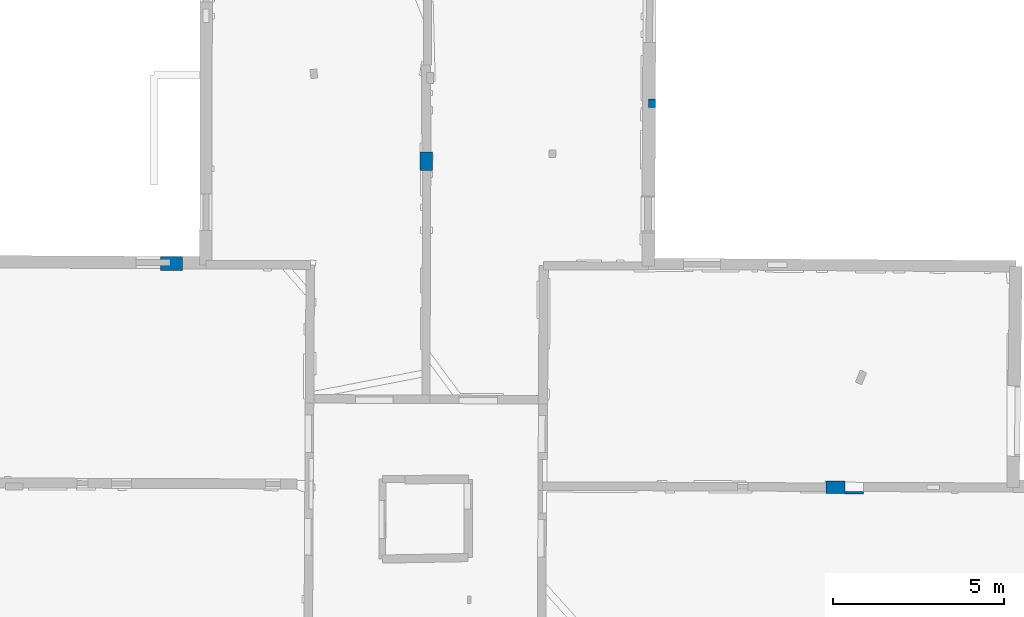
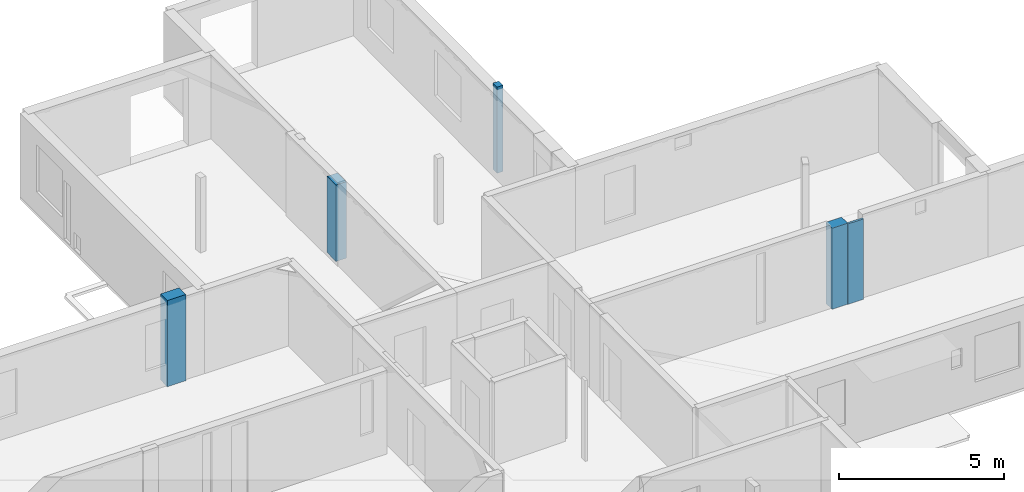
# One storey, part 2 of 17: 5 columns.
"""IFC2X3 building model written with IfcOpenShell, lengths in metres."""

from ifc_helpers import new_model, entity, si_unit, converted_unit, derived_unit, direction, frame, origin, origin_2d_with_axis, place, context, subcontext, project, spatial, rectangle, extrude, source, transform, mapped, material, type_object, type_shapes, element, save


model = new_model("IFC2X3")

# Units and contexts
model_context = context("Model", 3, precision=1e-05, world=origin(), true_north=direction((0.0, 1.0)))
body_context = subcontext(model_context, "Body", "Model", "MODEL_VIEW")
ifc_project = project(units=[si_unit("LENGTHUNIT", "METRE"), si_unit("AREAUNIT", "SQUARE_METRE"), si_unit("VOLUMEUNIT", "CUBIC_METRE"), converted_unit("PLANEANGLEUNIT", "DEGREE", entity("IfcRatioMeasure", 0.0174532925199433), si_unit("PLANEANGLEUNIT", "RADIAN"), dimensions=[0, 0, 0, 0, 0, 0, 0]), si_unit("MASSUNIT", "GRAM", prefix="KILO"), derived_unit("MASSDENSITYUNIT", [(si_unit("MASSUNIT", "GRAM", prefix="KILO"), 1), (si_unit("LENGTHUNIT", "METRE"), -3)]), derived_unit("MOMENTOFINERTIAUNIT", [(si_unit("LENGTHUNIT", "METRE"), 4)]), si_unit("TIMEUNIT", "SECOND"), si_unit("FREQUENCYUNIT", "HERTZ"), si_unit("THERMODYNAMICTEMPERATUREUNIT", "DEGREE_CELSIUS"), derived_unit("THERMALTRANSMITTANCEUNIT", [(si_unit("MASSUNIT", "GRAM", prefix="KILO"), 1), (si_unit("THERMODYNAMICTEMPERATUREUNIT", "KELVIN"), -1), (si_unit("TIMEUNIT", "SECOND"), -3)]), derived_unit("VOLUMETRICFLOWRATEUNIT", [(si_unit("LENGTHUNIT", "METRE"), 3), (si_unit("TIMEUNIT", "SECOND"), -1)]), si_unit("ELECTRICCURRENTUNIT", "AMPERE"), si_unit("ELECTRICVOLTAGEUNIT", "VOLT"), si_unit("POWERUNIT", "WATT"), si_unit("FORCEUNIT", "NEWTON", prefix="KILO"), si_unit("ILLUMINANCEUNIT", "LUX"), si_unit("LUMINOUSFLUXUNIT", "LUMEN"), si_unit("LUMINOUSINTENSITYUNIT", "CANDELA"), derived_unit("USERDEFINED", [(si_unit("MASSUNIT", "GRAM", prefix="KILO"), -1), (si_unit("LENGTHUNIT", "METRE"), -2), (si_unit("TIMEUNIT", "SECOND"), 3), (si_unit("LUMINOUSFLUXUNIT", "LUMEN"), 1)]), derived_unit("LINEARVELOCITYUNIT", [(si_unit("LENGTHUNIT", "METRE"), 1), (si_unit("TIMEUNIT", "SECOND"), -1)]), si_unit("PRESSUREUNIT", "PASCAL"), derived_unit("USERDEFINED", [(si_unit("LENGTHUNIT", "METRE"), -2), (si_unit("MASSUNIT", "GRAM", prefix="KILO"), 1), (si_unit("TIMEUNIT", "SECOND"), -2)]), derived_unit("LINEARFORCEUNIT", [(si_unit("MASSUNIT", "GRAM", prefix="KILO"), 1), (si_unit("LENGTHUNIT", "METRE"), 1), (si_unit("TIMEUNIT", "SECOND"), -2), (si_unit("LENGTHUNIT", "METRE"), -1)]), derived_unit("PLANARFORCEUNIT", [(si_unit("MASSUNIT", "GRAM", prefix="KILO"), 1), (si_unit("LENGTHUNIT", "METRE"), 1), (si_unit("TIMEUNIT", "SECOND"), -2), (si_unit("LENGTHUNIT", "METRE"), -2)])], contexts=[model_context])

# Site, building, storey
placement = place(None, origin())
site = spatial("IfcSite", under=ifc_project, at=placement, CompositionType="ELEMENT")
building = spatial("IfcBuilding", under=site, at=placement, CompositionType="ELEMENT")
storey_placement = place(placement, frame((0.0, 0.0, 12.0782108306885)))
storey = spatial("IfcBuildingStorey", under=building, at=storey_placement, Name="Level 5", CompositionType="ELEMENT", Elevation=12.0782108306885)

# Columns
ifc_material = material()
column_type_1 = type_object("IfcColumnType", Name="Rectangular Column:645 x 410mm", PredefinedType="COLUMN", material=ifc_material)
shared_shape_1 = source(origin(), body_context, "Body", "SweptSolid", [
    extrude(rectangle(XDim=0.6451854329522, YDim=0.409999996423721, at=origin_2d_with_axis()), frame((0.0, 0.0, 0.0), z_axis=(0.0, 0.0, 1.0), x_axis=(0.0, -1.0, 0.0)), (0.0, 0.0, 1.0), 3.1899995803833),
])
type_shapes(column_type_1, [shared_shape_1])
column_1_placement = place(placement, frame((-1.06502646466199, 64.1323137706845, 12.0790004730225), z_axis=(0.0, 0.0, 1.0), x_axis=(0.0053900170652912, 0.999985473752512, 0.0)))
element("IfcColumn", 1, at=column_1_placement, inside=storey, type_object=column_type_1, Name="Rectangular Column:645 x 410mm", ObjectType="Rectangular Column:645 x 410mm", context=body_context, shape_type="MappedRepresentation", body=[
    mapped(shared_shape_1, transform((0.0, 0.0, 0.0), scale=1.0)),
])
column_type_2 = type_object("IfcColumnType", Name="Rectangular Column:544 x 70mm", PredefinedType="COLUMN", material=ifc_material)
shared_shape_2 = source(origin(), body_context, "Body", "SweptSolid", [
    extrude(rectangle(XDim=0.544468560413648, YDim=0.0700000002980232, at=origin_2d_with_axis()), frame((0.0, 0.0, 0.0), z_axis=(0.0, 0.0, 1.0), x_axis=(0.0, -1.0, 0.0)), (0.0, 0.0, 1.0), 2.97499942779541),
])
type_shapes(column_type_2, [shared_shape_2])
column_2_placement = place(placement, frame((18.9210354156017, 57.418874873876, 12.0790004730225), z_axis=(0.0, 0.0, 1.0), x_axis=(0.00404270851562383, 0.99999182822054, 0.0)))
element("IfcColumn", 2, at=column_2_placement, inside=storey, type_object=column_type_2, Name="Rectangular Column:544 x 70mm", ObjectType="Rectangular Column:544 x 70mm", context=body_context, shape_type="MappedRepresentation", body=[
    mapped(shared_shape_2, transform((0.0, 0.0, 0.0), scale=1.0)),
])
column_type_3 = type_object("IfcColumnType", Name="Rectangular Column:540 x 360mm", PredefinedType="COLUMN", material=ifc_material)
shared_shape_3 = source(origin(), body_context, "Body", "SweptSolid", [
    extrude(rectangle(XDim=0.540002110337502, YDim=0.360000014305115, at=origin_2d_with_axis()), frame((0.0, 0.0, 0.0), z_axis=(0.0, 0.0, 1.0), x_axis=(0.0, -1.0, 0.0)), (0.0, 0.0, 1.0), 2.82999992370605),
])
type_shapes(column_type_3, [shared_shape_3])
column_3_placement = place(placement, frame((6.39011798156554, 67.1313309197889, 12.2749996185303), z_axis=(0.0, 0.0, 1.0), x_axis=(-0.999941270290532, 0.0108377105404324, 0.0)))
element("IfcColumn", 3, at=column_3_placement, inside=storey, type_object=column_type_3, Name="Rectangular Column:540 x 360mm", ObjectType="Rectangular Column:540 x 360mm", context=body_context, shape_type="MappedRepresentation", body=[
    mapped(shared_shape_3, transform((0.0, 0.0, 0.0), scale=1.0)),
])
column_type_4 = type_object("IfcColumnType", Name="Rectangular Column:252 x 200mm", PredefinedType="COLUMN", material=ifc_material)
shared_shape_4 = source(origin(), body_context, "Body", "SweptSolid", [
    extrude(rectangle(XDim=0.252086230336953, YDim=0.200000002980232, at=origin_2d_with_axis()), frame((0.0, 0.0, 0.0), z_axis=(0.0, 0.0, 1.0), x_axis=(0.0, -1.0, 0.0)), (0.0, 0.0, 1.0), 3.1899995803833),
])
type_shapes(column_type_4, [shared_shape_4])
column_4_placement = place(placement, frame((13.0056512976084, 68.8230257526845, 12.0790004730225), z_axis=(0.0, 0.0, 1.0), x_axis=(0.999986490215826, -0.00519801749063171, 0.0)))
element("IfcColumn", 4, at=column_4_placement, inside=storey, type_object=column_type_4, Name="Rectangular Column:252 x 200mm", ObjectType="Rectangular Column:252 x 200mm", context=body_context, shape_type="MappedRepresentation", body=[
    mapped(shared_shape_4, transform((0.0, 0.0, 0.0), scale=1.0)),
])
column_type_5 = type_object("IfcColumnType", Name="Rectangular Column:552 x 370mm", PredefinedType="COLUMN", material=ifc_material)
shared_shape_5 = source(origin(), body_context, "Body", "SweptSolid", [
    extrude(rectangle(XDim=0.551510017618614, YDim=0.370000004768372, at=origin_2d_with_axis()), frame((0.0, 0.0, 0.0), z_axis=(0.0, 0.0, 1.0), x_axis=(0.0, -1.0, 0.0)), (0.0, 0.0, 1.0), 2.99799919128418),
])
type_shapes(column_type_5, [shared_shape_5])
column_5_placement = place(placement, frame((18.37593844173, 57.5828547733449, 12.0790004730225), z_axis=(0.0, 0.0, 1.0), x_axis=(-0.0079233708546506, 0.999968609604471, 0.0)))
element("IfcColumn", 5, at=column_5_placement, inside=storey, type_object=column_type_5, Name="Rectangular Column:552 x 370mm", ObjectType="Rectangular Column:552 x 370mm", context=body_context, shape_type="MappedRepresentation", body=[
    mapped(shared_shape_5, transform((0.0, 0.0, 0.0), scale=1.0)),
])

save(model, "model.ifc")
